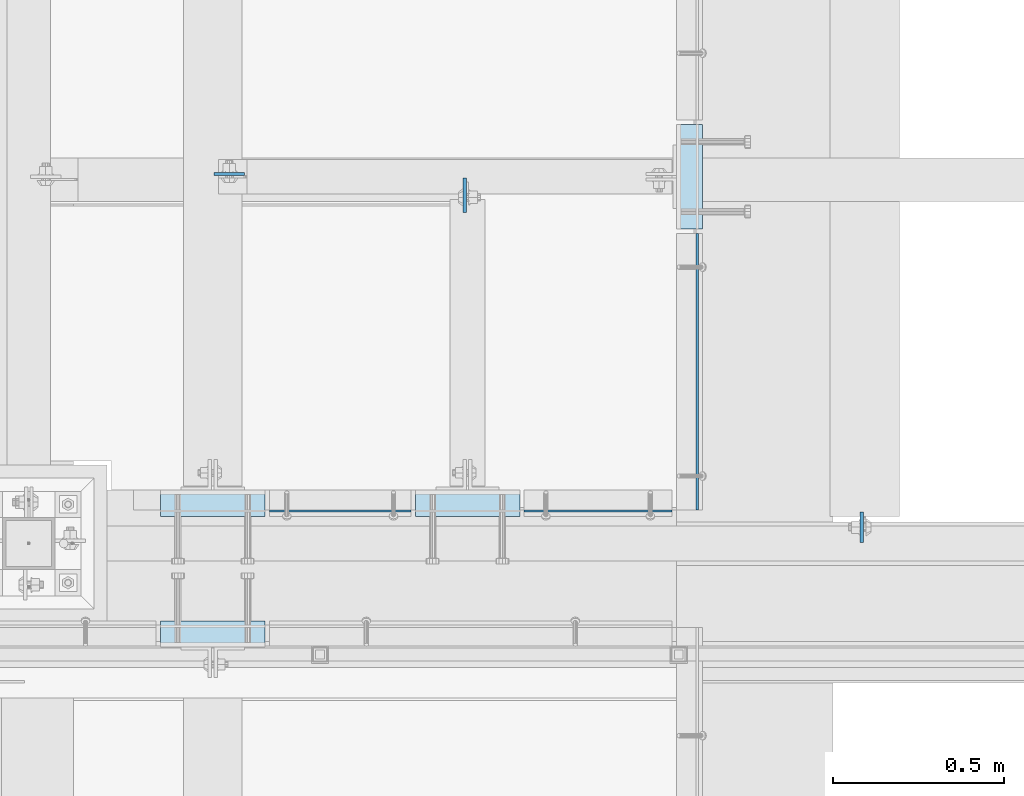
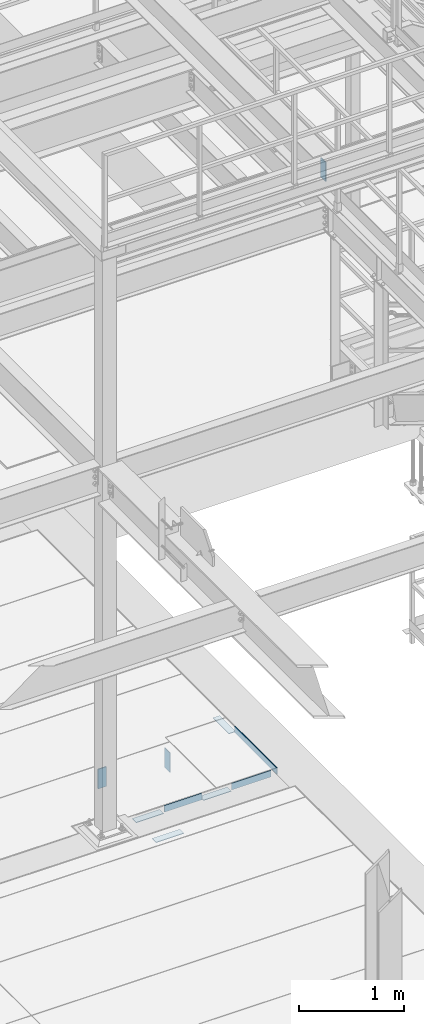
# One storey, part 3107 of 3843: 10 plates, 10 elements without a shape of their own.
"""IFC2X3 building model written with IfcOpenShell, lengths in millimetres."""

from ifc_helpers import new_model, si_unit, frame, origin_with_axes, place, context, subcontext, project, spatial, faceted_brep, material, type_object, element, aggregate, save


model = new_model("IFC2X3")

# Units and contexts
model_context = context("Model", 3, precision=1e-05, world=origin_with_axes())
body_context = subcontext(model_context, "Body", "Model", "MODEL_VIEW")
ifc_project = project(units=[si_unit("LENGTHUNIT", "METRE", prefix="MILLI"), si_unit("AREAUNIT", "SQUARE_METRE"), si_unit("VOLUMEUNIT", "CUBIC_METRE"), si_unit("MASSUNIT", "GRAM", prefix="KILO"), si_unit("TIMEUNIT", "SECOND"), si_unit("PLANEANGLEUNIT", "RADIAN"), si_unit("SOLIDANGLEUNIT", "STERADIAN"), si_unit("THERMODYNAMICTEMPERATUREUNIT", "DEGREE_CELSIUS"), si_unit("LUMINOUSINTENSITYUNIT", "LUMEN")], contexts=[model_context])

# Site, building, storey
site_placement = place(None, origin_with_axes())
site = spatial("IfcSite", under=ifc_project, at=site_placement, CompositionType="ELEMENT")
building_placement = place(site_placement, origin_with_axes())
building = spatial("IfcBuilding", under=site, at=building_placement, Name="Undefined", CompositionType="ELEMENT")
storey_placement = place(building_placement, origin_with_axes())
storey = spatial("IfcBuildingStorey", under=building, at=storey_placement, Name="Undefined", CompositionType="ELEMENT", Elevation=0.0)

# Assembly, plate
assembly_1_placement = place(storey_placement, origin_with_axes())
assembly_1 = element("IfcElementAssembly", 1, at=assembly_1_placement, inside=storey, Name="EMBED PLATE", AssemblyPlace="NOTDEFINED", PredefinedType="RIGID_FRAME")
ifc_material_1 = material(Name="STEEL/A36")
plate_type_1 = type_object("IfcPlateType", PredefinedType="NOTDEFINED")
plate_1_placement = place(assembly_1_placement, frame((50885.7081745315, 21224.875, 30400.625), z_axis=(0.0, 1.0, 0.0), x_axis=(1.0, 0.0, 0.0)))
plate_1 = element("IfcPlate", 2, at=plate_1_placement, type_object=plate_type_1, material=ifc_material_1, Name="PLATE", context=body_context, shape_type="Brep", body=[
    faceted_brep([(0.0, -3.17499999999927, 0.0), (0.0, -3.17499999999927, 304.800000000003), (0.0, 3.17499999999927, 304.800000000003), (0.0, 3.17499999999927, 0.0), (76.1999999999971, -3.17499999999927, 304.799999999996), (76.1999999999971, 3.17499999999927, 304.799999999996), (76.1999999999971, -3.17499999999927, 0.0), (76.1999999999971, 3.17499999999927, 0.0)], [[[0, 1, 2, 3]], [[1, 4, 5, 2]], [[4, 6, 7, 5]], [[6, 0, 3, 7]], [[5, 7, 3, 2]], [[6, 4, 1, 0]]]),
])
aggregate(assembly_1, [plate_1])

assembly_2_placement = place(storey_placement, origin_with_axes())
assembly_2 = element("IfcElementAssembly", 3, at=assembly_2_placement, inside=storey, Name="EMBED PLATE", AssemblyPlace="NOTDEFINED", PredefinedType="RIGID_FRAME")
plate_2_placement = place(assembly_2_placement, frame((49685.575, 20005.6749969482, 30400.625), z_axis=(-1.0, 0.0, 0.0), x_axis=(0.0, 1.0, 0.0)))
plate_2 = element("IfcPlate", 4, at=plate_2_placement, type_object=plate_type_1, material=ifc_material_1, Name="PLATE", context=body_context, shape_type="Brep", body=[
    faceted_brep([(0.0, -3.17499999999927, 0.0), (0.0, -3.17499999999927, 304.800000000003), (0.0, 3.17499999999927, 304.800000000003), (0.0, 3.17499999999927, 0.0), (76.1999999999971, -3.17499999999927, 304.799999999996), (76.1999999999971, 3.17499999999927, 304.799999999996), (76.1999999999971, -3.17499999999927, 0.0), (76.1999999999971, 3.17499999999927, 0.0)], [[[0, 1, 2, 3]], [[1, 4, 5, 2]], [[4, 6, 7, 5]], [[6, 0, 3, 7]], [[5, 7, 3, 2]], [[6, 4, 1, 0]]]),
])
aggregate(assembly_2, [plate_2])

assembly_3_placement = place(storey_placement, origin_with_axes())
assembly_3 = element("IfcElementAssembly", 5, at=assembly_3_placement, inside=storey, Name="EMBED PLATE", AssemblyPlace="NOTDEFINED", PredefinedType="RIGID_FRAME")
plate_3_placement = place(assembly_3_placement, frame((50123.725, 20462.8750030517, 30400.625), z_axis=(1.0, 0.0, 0.0), x_axis=(0.0, -1.0, 0.0)))
plate_3 = element("IfcPlate", 6, at=plate_3_placement, type_object=plate_type_1, material=ifc_material_1, Name="PLATE", context=body_context, shape_type="Brep", body=[
    faceted_brep([(0.0, -3.17499999999927, 0.0), (0.0, -3.17499999999927, 304.800000000003), (0.0, 3.17499999999927, 304.800000000003), (0.0, 3.17499999999927, 0.0), (76.1999999999971, -3.17499999999927, 304.799999999996), (76.1999999999971, 3.17499999999927, 304.799999999996), (76.1999999999971, -3.17499999999927, 0.0), (76.1999999999971, 3.17499999999927, 0.0)], [[[0, 1, 2, 3]], [[1, 4, 5, 2]], [[4, 6, 7, 5]], [[6, 0, 3, 7]], [[5, 7, 3, 2]], [[6, 4, 1, 0]]]),
])
aggregate(assembly_3, [plate_3])

assembly_4_placement = place(storey_placement, origin_with_axes())
assembly_4 = element("IfcElementAssembly", 7, at=assembly_4_placement, inside=storey, Name="EMBED PLATE", AssemblyPlace="NOTDEFINED", PredefinedType="RIGID_FRAME")
plate_4_placement = place(assembly_4_placement, frame((49380.775, 20462.8750030517, 30400.625), z_axis=(1.0, 0.0, 0.0), x_axis=(0.0, -1.0, 0.0)))
plate_4 = element("IfcPlate", 8, at=plate_4_placement, type_object=plate_type_1, material=ifc_material_1, Name="PLATE", context=body_context, shape_type="Brep", body=[
    faceted_brep([(0.0, -3.17499999999927, 0.0), (0.0, -3.17499999999927, 304.800000000003), (0.0, 3.17499999999927, 304.800000000003), (0.0, 3.17499999999927, 0.0), (76.1999999999971, -3.17499999999927, 304.799999999996), (76.1999999999971, 3.17499999999927, 304.799999999996), (76.1999999999971, -3.17499999999927, 0.0), (76.1999999999971, 3.17499999999927, 0.0)], [[[0, 1, 2, 3]], [[1, 4, 5, 2]], [[4, 6, 7, 5]], [[6, 0, 3, 7]], [[5, 7, 3, 2]], [[6, 4, 1, 0]]]),
])
aggregate(assembly_4, [plate_4])

assembly_5_placement = place(storey_placement, origin_with_axes())
assembly_5 = element("IfcElementAssembly", 9, at=assembly_5_placement, inside=storey, Name="ANGLE", AssemblyPlace="NOTDEFINED", PredefinedType="RIGID_FRAME")
plate_5_placement = place(assembly_5_placement, frame((50946.0499996952, 20405.7248833402, 30403.8000030518), z_axis=(0.0, 0.999999999997942, -2.02899998962774e-06), x_axis=(0.0, 2.02899999567308e-06, 0.999999999997942)))
plate_5 = element("IfcPlate", 10, at=plate_5_placement, type_object=plate_type_1, material=ifc_material_1, Name="PLATE", context=body_context, shape_type="Brep", body=[
    faceted_brep([(0.0, -3.17499999999927, 0.0), (0.00108199702663114, -3.17500000000291, 806.450036627399), (0.00108199702663114, 3.17500000000291, 806.450036627399), (0.0, 3.17499999999927, 0.0), (76.2010812158915, -3.17500000000291, 806.449975592201), (76.2010812158915, 3.17500000000291, 806.449975592201), (76.1999999999971, -3.17499999999927, 0.0), (76.1999999999971, 3.17499999999927, 0.0)], [[[0, 1, 2, 3]], [[1, 4, 5, 2]], [[4, 6, 7, 5]], [[6, 0, 3, 7]], [[5, 7, 3, 2]], [[6, 4, 1, 0]]]),
])
aggregate(assembly_5, [plate_5])

assembly_6_placement = place(storey_placement, origin_with_axes())
assembly_6 = element("IfcElementAssembly", 11, at=assembly_6_placement, inside=storey, Name="ANGLE", AssemblyPlace="NOTDEFINED", PredefinedType="RIGID_FRAME")
plate_6_placement = place(assembly_6_placement, frame((50441.2250126186, 20402.5485512552, 30403.8000030518), z_axis=(0.99999999999915, 1.30400000489317e-06, 0.0), x_axis=(0.0, 0.0, 1.0)))
plate_6 = element("IfcPlate", 12, at=plate_6_placement, type_object=plate_type_1, material=ifc_material_1, Name="PLATE", context=body_context, shape_type="Brep", body=[
    faceted_brep([(0.0, -3.17499999999927, 0.0), (-1.03997081168927e-05, -3.17499999999927, 431.799987792969), (-1.03997081168927e-05, 3.17499999999927, 431.799987792969), (0.0, 3.17499999999927, 0.0), (76.1999893189823, -3.17499999999927, 431.799987793223), (76.1999893189823, 3.17499999999927, 431.799987793223), (76.1999999999971, -3.17499999999927, 0.0), (76.1999999999971, 3.17499999999927, 0.0)], [[[0, 1, 2, 3]], [[1, 4, 5, 2]], [[4, 6, 7, 5]], [[6, 0, 3, 7]], [[5, 7, 3, 2]], [[6, 4, 1, 0]]]),
])
aggregate(assembly_6, [plate_6])

assembly_7_placement = place(storey_placement, origin_with_axes())
assembly_7 = element("IfcElementAssembly", 13, at=assembly_7_placement, inside=storey, Name="ANGLE", AssemblyPlace="NOTDEFINED", PredefinedType="RIGID_FRAME")
plate_7_placement = place(assembly_7_placement, frame((49698.2749651289, 20402.5486971153, 30403.8000030518), z_axis=(0.99999999999915, 1.30400000489317e-06, 0.0), x_axis=(0.0, 0.0, 1.0)))
plate_7 = element("IfcPlate", 14, at=plate_7_placement, type_object=plate_type_1, material=ifc_material_1, Name="PLATE", context=body_context, shape_type="Brep", body=[
    faceted_brep([(0.0, -3.17499999999927, 0.0), (-1.00761426438112e-05, -3.17499999982101, 412.750012208846), (-1.00761426438112e-05, 3.17500000018481, 412.750012208831), (0.0, 3.17499999999927, 0.0), (76.1999892724925, -3.17499999981919, 412.750012209093), (76.1999892724925, 3.17500000018481, 412.750012209079), (76.1999999999971, -3.17499999999927, 0.0), (76.1999999999971, 3.17499999999927, 0.0)], [[[0, 1, 2, 3]], [[1, 4, 5, 2]], [[4, 6, 7, 5]], [[6, 0, 3, 7]], [[5, 7, 3, 2]], [[6, 4, 1, 0]]]),
])
aggregate(assembly_7, [plate_7])

assembly_8_placement = place(storey_placement, origin_with_axes())
assembly_8 = element("IfcElementAssembly", 15, at=assembly_8_placement, inside=storey, Name="BEAM", AssemblyPlace="NOTDEFINED", PredefinedType="RIGID_FRAME")
ifc_material_2 = material(Name="STEEL/A572-50")
plate_type_2 = type_object("IfcPlateType", PredefinedType="NOTDEFINED")
plate_8_placement = place(assembly_8_placement, frame((49537.14375, 21385.2125, 30365.7), z_axis=(1.0, 0.0, 0.0), x_axis=(0.0, 0.0, -1.0)))
plate_8 = element("IfcPlate", 16, at=plate_8_placement, type_object=plate_type_2, material=ifc_material_2, Name="PLATE", context=body_context, shape_type="Brep", body=[
    faceted_brep([(0.0, -4.76249999999709, 0.0), (0.0, -4.76249999999709, 88.9000015258789), (0.0, 4.76249999999709, 88.9000015258789), (0.0, 4.76249999999709, 0.0), (228.600006102781, -4.7625000004191, 88.9000015257589), (228.600006102781, 4.76249999954598, 88.9000015257443), (228.600006103079, -4.7625000004482, 7.27595761418343e-12), (228.600006103079, 4.76249999954598, -7.27595761418343e-12)], [[[0, 1, 2, 3]], [[1, 4, 5, 2]], [[4, 6, 7, 5]], [[6, 0, 3, 7]], [[5, 7, 3, 2]], [[6, 4, 1, 0]]]),
])
aggregate(assembly_8, [plate_8])

assembly_9_placement = place(storey_placement, origin_with_axes())
assembly_9 = element("IfcElementAssembly", 17, at=assembly_9_placement, inside=storey, Name="BEAM", AssemblyPlace="NOTDEFINED", PredefinedType="RIGID_FRAME")
plate_9_placement = place(assembly_9_placement, frame((51426.26875, 20310.475, 37426.9), z_axis=(0.0, 1.0, 0.0), x_axis=(0.0, 0.0, -1.0)))
plate_9 = element("IfcPlate", 18, at=plate_9_placement, type_object=plate_type_2, material=ifc_material_2, Name="PLATE", context=body_context, shape_type="Brep", body=[
    faceted_brep([(0.0, -4.76249999999709, 0.0), (0.0, -4.76249999999709, 88.9000015258789), (0.0, 4.76249999999709, 88.9000015258789), (0.0, 4.76249999999709, 0.0), (228.600006102781, -4.7625000004191, 88.9000015257589), (228.600006102781, 4.76249999954598, 88.9000015257443), (228.600006103079, -4.7625000004482, 7.27595761418343e-12), (228.600006103079, 4.76249999954598, -7.27595761418343e-12)], [[[0, 1, 2, 3]], [[1, 4, 5, 2]], [[4, 6, 7, 5]], [[6, 0, 3, 7]], [[5, 7, 3, 2]], [[6, 4, 1, 0]]]),
])
aggregate(assembly_9, [plate_9])

assembly_10_placement = place(storey_placement, origin_with_axes())
assembly_10 = element("IfcElementAssembly", 19, at=assembly_10_placement, inside=storey, Name="BEAM", AssemblyPlace="NOTDEFINED", PredefinedType="RIGID_FRAME")
plate_type_3 = type_object("IfcPlateType", PredefinedType="NOTDEFINED")
plate_10_placement = place(assembly_10_placement, frame((50268.1875, 21374.1, 30365.7), z_axis=(0.0, -1.0, 0.0), x_axis=(0.0, 0.0, -1.0)))
plate_10 = element("IfcPlate", 20, at=plate_10_placement, type_object=plate_type_3, material=ifc_material_2, Name="PLATE", context=body_context, shape_type="Brep", body=[
    faceted_brep([(0.0, -4.76249999999709, 0.0), (0.0, -4.76249999999709, 101.599999999999), (0.0, 4.76249999999709, 101.599999999999), (0.0, 4.76249999999709, 0.0), (228.600006103516, -4.76249999999709, 101.599998474121), (228.600006103516, 4.76249999999709, 101.599998474121), (228.600006103079, -4.7625000004482, 7.27595761418343e-12), (228.600006103079, 4.76249999954598, -7.27595761418343e-12)], [[[0, 1, 2, 3]], [[1, 4, 5, 2]], [[4, 6, 7, 5]], [[6, 0, 3, 7]], [[5, 7, 3, 2]], [[6, 4, 1, 0]]]),
])
aggregate(assembly_10, [plate_10])

save(model, "model.ifc")
